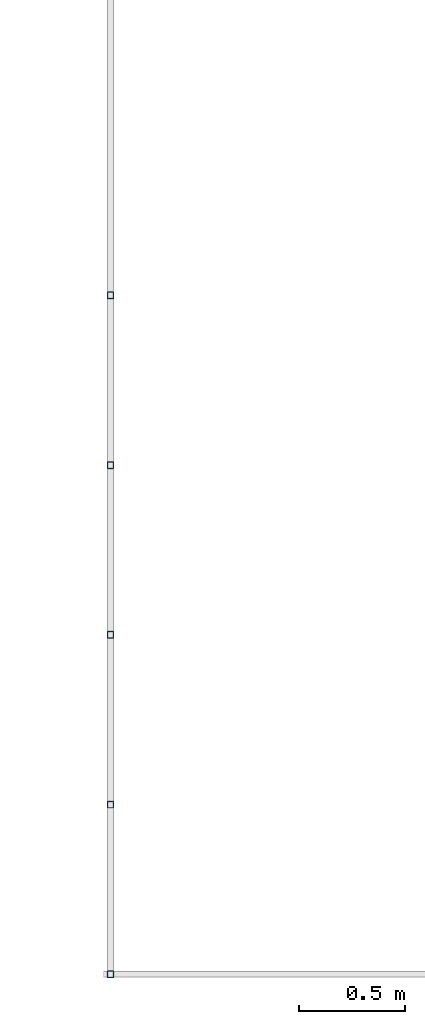
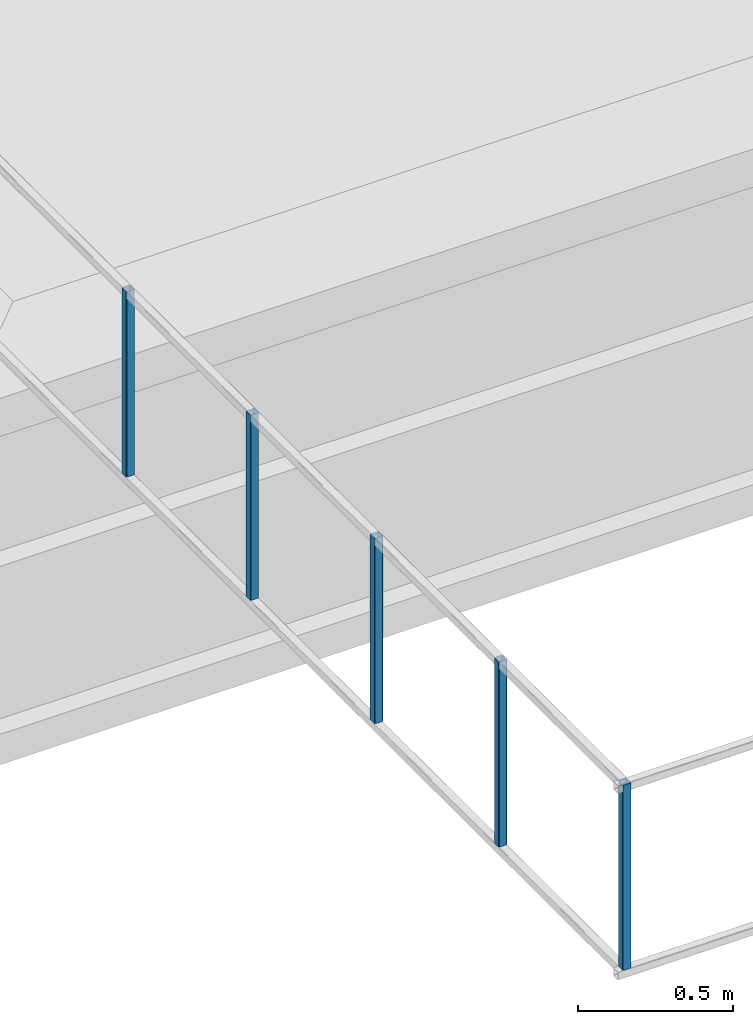
# One storey, part 3 of 7: 5 beams.
"""IFC4X3_ADD2 building model written with IfcOpenShell, lengths in metres."""

from ifc_helpers import new_model, entity, si_unit, converted_unit, frame, origin_with_axes, origin_2d_with_axis, place, context, subcontext, project, spatial, hollow_rectangle, extrude, material, material_profile, profile_set, profile_usage, type_object, element, save


model = new_model("IFC4X3_ADD2")

# Units and contexts
model_context = context("Model", 3, precision=1e-05, world=origin_with_axes())
plan_context = context("Plan", 2, precision=1e-05, world=origin_2d_with_axis())
body_context = subcontext(model_context, "Body", "Model", "MODEL_VIEW")
ifc_project = project(units=[si_unit("VOLUMEUNIT", "CUBIC_METRE"), si_unit("LENGTHUNIT", "METRE"), converted_unit("PLANEANGLEUNIT", "degree", entity("IfcReal", 0.0174532925199433), si_unit("PLANEANGLEUNIT", "RADIAN"), dimensions=[0, 0, 0, 0, 0, 0, 0]), si_unit("AREAUNIT", "SQUARE_METRE")], contexts=[model_context, plan_context])

# Site, building, storey
site_placement = place(None, origin_with_axes())
site = spatial("IfcSite", under=ifc_project, at=site_placement)
building_placement = place(site_placement, origin_with_axes())
building = spatial("IfcBuilding", under=site, at=building_placement, Name="Building")
storey_placement = place(building_placement, frame((0.0, 0.0, -0.870000004768372), z_axis=(0.0, 0.0, 1.0), x_axis=(1.0, 0.0, 0.0)))
storey = spatial("IfcBuildingStorey", under=building, at=storey_placement, Name="Footing")

# Beams
ifc_material = material(Name="Brick")
ifc_material_profile = material_profile(ifc_material, hollow_rectangle(XDim=0.0320000015199184, YDim=0.0320000015199184, WallThickness=0.0020000000949949, InnerFilletRadius=0.0020000000949949, OuterFilletRadius=0.00400000018998981))
ifc_profile_set = profile_set([ifc_material_profile])
ifc_profile_usage_1 = profile_usage(ifc_profile_set, cardinal=5)
beam_type = type_object("IfcBeamType", Name="SHS_0.032x0.032x0", PredefinedType="BEAM", material=ifc_profile_set)
beam_1_placement = place(storey_placement, frame((5.39050388336182, 4.94458627700806, 3.84210193157196), z_axis=(-1.50995830949793e-07, 1.19209246918215e-07, 0.999999999999982), x_axis=(0.999999999999973, 1.74845553146947e-07, 1.50995816738937e-07)))
element("IfcBeam", 1, at=beam_1_placement, inside=storey, type_object=beam_type, material=ifc_profile_usage_1, Name="Beam", context=body_context, shape_type="SweptSolid", body=[
    extrude(hollow_rectangle(XDim=0.0320000015199184, YDim=0.0320000015199184, WallThickness=0.0020000000949949, InnerFilletRadius=0.0020000000949949, OuterFilletRadius=0.00400000018998981), origin_with_axes(), (0.0, 0.0, 1.0), 0.72810028754607),
])
ifc_profile_usage_2 = profile_usage(ifc_profile_set, cardinal=5)
beam_2_placement = place(storey_placement, frame((5.39050388336182, 5.74458646774292, 3.84210193157196), z_axis=(-1.50995816738939e-07, 1.19209246918215e-07, 0.999999999999982), x_axis=(0.999999999999973, 1.74845567357802e-07, 1.50995802528083e-07)))
element("IfcBeam", 2, at=beam_2_placement, inside=storey, type_object=beam_type, material=ifc_profile_usage_2, Name="Beam", context=body_context, shape_type="SweptSolid", body=[
    extrude(hollow_rectangle(XDim=0.0320000015199184, YDim=0.0320000015199184, WallThickness=0.0020000000949949, InnerFilletRadius=0.0020000000949949, OuterFilletRadius=0.00400000018998981), origin_with_axes(), (0.0, 0.0, 1.0), 0.72810028754607),
])
ifc_profile_usage_3 = profile_usage(ifc_profile_set, cardinal=5)
beam_3_placement = place(storey_placement, frame((5.39050340652466, 6.54458618164062, 3.84210169315338), z_axis=(-1.50995816738939e-07, 1.19209246918215e-07, 0.999999999999982), x_axis=(0.999999999999973, 1.74845567357802e-07, 1.50995802528083e-07)))
element("IfcBeam", 3, at=beam_3_placement, inside=storey, type_object=beam_type, material=ifc_profile_usage_3, Name="Beam", context=body_context, shape_type="SweptSolid", body=[
    extrude(hollow_rectangle(XDim=0.0320000015199184, YDim=0.0320000015199184, WallThickness=0.0020000000949949, InnerFilletRadius=0.0020000000949949, OuterFilletRadius=0.00400000018998981), origin_with_axes(), (0.0, 0.0, 1.0), 0.72810028754607),
])
ifc_profile_usage_4 = profile_usage(ifc_profile_set, cardinal=5)
beam_4_placement = place(storey_placement, frame((5.39050340652466, 7.34458637237549, 3.84210169315338), z_axis=(-1.50995816738939e-07, 1.19209246918215e-07, 0.999999999999982), x_axis=(0.999999999999973, 1.74845567357802e-07, 1.50995802528083e-07)))
element("IfcBeam", 4, at=beam_4_placement, inside=storey, type_object=beam_type, material=ifc_profile_usage_4, Name="Beam", context=body_context, shape_type="SweptSolid", body=[
    extrude(hollow_rectangle(XDim=0.0320000015199184, YDim=0.0320000015199184, WallThickness=0.0020000000949949, InnerFilletRadius=0.0020000000949949, OuterFilletRadius=0.00400000018998981), origin_with_axes(), (0.0, 0.0, 1.0), 0.72810028754607),
])
ifc_profile_usage_5 = profile_usage(ifc_profile_set, cardinal=5)
beam_5_placement = place(storey_placement, frame((5.39050340652466, 8.14458656311035, 3.8421014547348), z_axis=(-1.50995816738939e-07, 1.19209246918215e-07, 0.999999999999982), x_axis=(0.999999999999973, 1.74845567357802e-07, 1.50995802528083e-07)))
element("IfcBeam", 5, at=beam_5_placement, inside=storey, type_object=beam_type, material=ifc_profile_usage_5, Name="Beam", context=body_context, shape_type="SweptSolid", body=[
    extrude(hollow_rectangle(XDim=0.0320000015199184, YDim=0.0320000015199184, WallThickness=0.0020000000949949, InnerFilletRadius=0.0020000000949949, OuterFilletRadius=0.00400000018998981), origin_with_axes(), (0.0, 0.0, 1.0), 0.72810028754607),
])

save(model, "model.ifc")
